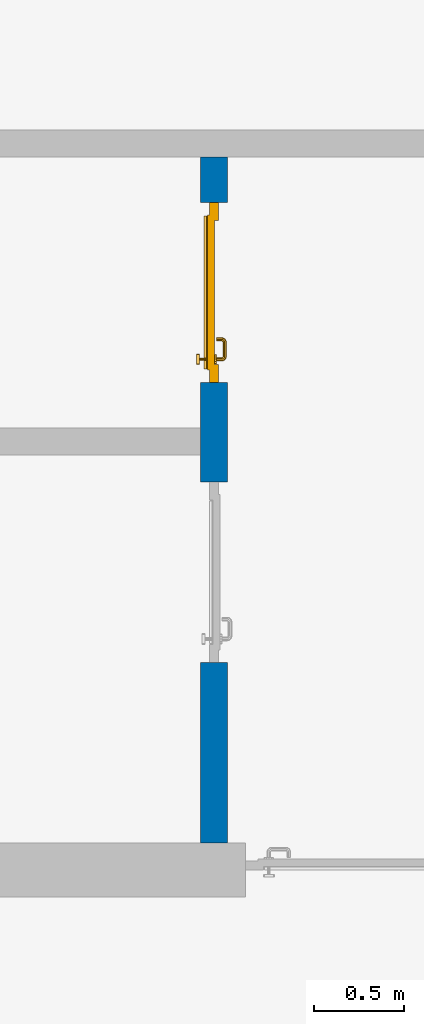
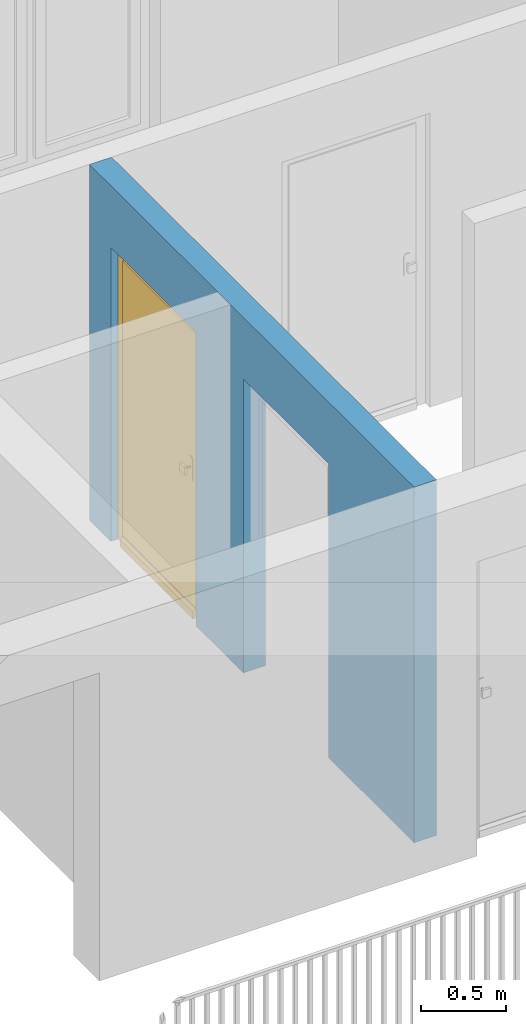
# One storey, part 18 of 54: 1 door, 1 wall, 2 openings.
"""IFC4 building model written with IfcOpenShell, lengths in metres."""

import ifcopenshell
import ifcopenshell.guid

model = None  # the IFC model being written
_history = None  # IfcOwnerHistory: only IFC2X3 demands one
_inside = {}  # id of a spatial element -> (the spatial element, [elements in it])
_under = {}  # id of a project, library or spatial element -> (it, [spatial elements below it])
_declared = {}  # id of a project -> (the project, [libraries it declares])
_typed = {}  # id of a type object -> (the type object, [elements of that type])
_made_of = {}  # id of a material, layer set ... -> (it, [elements and type objects made of it])


def new_model(schema):
    """Start an empty IFC model of exactly this schema.

    Asked for "IFC4X3", IfcOpenShell would pick the latest addendum, in which some entities
    have other attributes; the version numbers below select the first issue.
    IFC2X3 requires an IfcOwnerHistory on every rooted entity: one is made here for all.
    """
    global model, _history
    if schema == "IFC4X3":
        model = ifcopenshell.file(schema_version=(4, 3, 0, 0))
    else:
        model = ifcopenshell.file(schema=schema)
    _inside.clear()
    _under.clear()
    _declared.clear()
    _typed.clear()
    _made_of.clear()
    _history = None
    if model.schema == "IFC2X3":
        org = make("IfcOrganization", Name="unknown")
        user = make(
            "IfcPersonAndOrganization",
            ThePerson=make("IfcPerson", FamilyName="unknown"),
            TheOrganization=org,
        )
        app = make(
            "IfcApplication",
            ApplicationDeveloper=org,
            Version="unknown",
            ApplicationFullName="unknown",
            ApplicationIdentifier="unknown",
        )
        _history = make(
            "IfcOwnerHistory",
            OwningUser=user,
            OwningApplication=app,
            ChangeAction="ADDED",
            CreationDate=0,
        )
    return model


def make(cls, **values):
    """One entity of the class cls with the attributes given. An attribute that is None is left unset."""
    return model.create_entity(
        cls, **{name: value for name, value in values.items() if value is not None}
    )


def entity(cls, *values):
    """Any entity or typed value of the class cls, its attributes in the order of the schema. None: left unset."""
    e = model.create_entity(cls)
    for i, value in enumerate(values):
        if value is not None:
            e[i] = value
    return e


def rooted(cls, **values):
    """An entity with a GlobalId (a new one), such as an element, a storey or a relation."""
    return make(cls, GlobalId=ifcopenshell.guid.new(), OwnerHistory=_history, **values)


def si_unit(unit_type, name, prefix=None):
    """IfcSIUnit, for example si_unit("LENGTHUNIT", "METRE", prefix="MILLI")."""
    return make("IfcSIUnit", UnitType=unit_type, Prefix=prefix, Name=name)


def converted_unit(unit_type, name, factor, base, dimensions=None, offset=None):
    """IfcConversionBasedUnit, such as the inch: factor (a typed value) times the base unit."""
    return make(
        "IfcConversionBasedUnit"
        if offset is None
        else "IfcConversionBasedUnitWithOffset",
        ConversionOffset=offset,
        Dimensions=None
        if dimensions is None
        else entity("IfcDimensionalExponents", *dimensions),
        UnitType=unit_type,
        Name=name,
        ConversionFactor=make(
            "IfcMeasureWithUnit", ValueComponent=factor, UnitComponent=base
        ),
    )


def derived_unit(unit_type, elements):
    """IfcDerivedUnit: a product of units, each with its exponent."""
    return make(
        "IfcDerivedUnit",
        Elements=[
            make("IfcDerivedUnitElement", Unit=unit, Exponent=power)
            for unit, power in elements
        ],
        UnitType=unit_type,
    )


def assignment(units):
    """IfcUnitAssignment: the units of a project."""
    return None if units is None else make("IfcUnitAssignment", Units=units)


def point(xyz):
    """IfcCartesianPoint."""
    return None if xyz is None else make("IfcCartesianPoint", Coordinates=xyz)


def direction(xyz):
    """IfcDirection."""
    return None if xyz is None else make("IfcDirection", DirectionRatios=xyz)


def frame(location, z_axis=None, x_axis=None):
    """IfcAxis2Placement3D, a coordinate frame: its origin and axes. An axis left out is left unset."""
    return make(
        "IfcAxis2Placement3D",
        Location=point(location),
        Axis=direction(z_axis),
        RefDirection=direction(x_axis),
    )


def origin_with_axes():
    """The frame at (0, 0, 0) with the z axis (0, 0, 1) and the x axis (1, 0, 0) written out."""
    return frame((0.0, 0.0, 0.0), z_axis=(0.0, 0.0, 1.0), x_axis=(1.0, 0.0, 0.0))


def place(relative_to, where):
    """IfcLocalPlacement: puts the frame where relative to a parent placement (None: the world)."""
    return make(
        "IfcLocalPlacement", PlacementRelTo=relative_to, RelativePlacement=where
    )


def context(
    kind, dimensions, precision=None, world=None, true_north=None, identifier=None
):
    """IfcGeometricRepresentationContext, for example the 3D "Model" context."""
    return make(
        "IfcGeometricRepresentationContext",
        ContextIdentifier=identifier,
        ContextType=kind,
        CoordinateSpaceDimension=dimensions,
        Precision=precision,
        WorldCoordinateSystem=world,
        TrueNorth=true_north,
    )


def subcontext(parent, identifier, kind, view, scale=None):
    """IfcGeometricRepresentationSubContext, for example "Body" below "Model"."""
    return make(
        "IfcGeometricRepresentationSubContext",
        ContextIdentifier=identifier,
        ContextType=kind,
        ParentContext=parent,
        TargetScale=scale,
        TargetView=view,
    )


def project(units=None, contexts=None):
    """IfcProject with its units and contexts."""
    return rooted(
        "IfcProject",
        Name="project",
        RepresentationContexts=contexts,
        UnitsInContext=assignment(units),
    )


def spatial(cls, under=None, at=None, **own):
    """A site, building, storey or space (cls), placed at a placement, below another one or the project."""
    s = rooted(cls, ObjectPlacement=at, **own)
    if under is not None:
        _under.setdefault(under.id(), (under, []))[1].append(s)
    return s


def point_list(points):
    """IfcCartesianPointList2D or 3D."""
    cls = (
        "IfcCartesianPointList2D" if len(points[0]) == 2 else "IfcCartesianPointList3D"
    )
    return make(cls, CoordList=points)


def polygons(points, faces, closed=None, point_numbers=None):
    """IfcPolygonalFaceSet: a face is its outer loop, then its inner loops; points numbered from 1."""
    made = []
    for loops in faces:
        if len(loops) == 1:
            made.append(make("IfcIndexedPolygonalFace", CoordIndex=loops[0]))
        else:
            made.append(
                make(
                    "IfcIndexedPolygonalFaceWithVoids",
                    CoordIndex=loops[0],
                    InnerCoordIndices=loops[1:],
                )
            )
    return make(
        "IfcPolygonalFaceSet",
        Coordinates=point_list(points),
        Closed=closed,
        Faces=made,
        PnIndex=point_numbers,
    )


def shape(context_of_items, identifier, shape_type, items):
    """IfcShapeRepresentation: the items that make up one representation, for example the "Body"."""
    return make(
        "IfcShapeRepresentation",
        ContextOfItems=context_of_items,
        RepresentationIdentifier=identifier,
        RepresentationType=shape_type,
        Items=items,
    )


def source(mapping_origin, context_of_items, identifier, shape_type, items):
    """IfcRepresentationMap: a shape defined once, which mapped items show again and again."""
    return make(
        "IfcRepresentationMap",
        MappingOrigin=mapping_origin,
        MappedRepresentation=shape(context_of_items, identifier, shape_type, items),
    )


def transform(
    local_origin,
    x_axis=None,
    y_axis=None,
    z_axis=None,
    scale=None,
    scale2=None,
    scale3=None,
    uniform=True,
):
    """IfcCartesianTransformationOperator3D, or its non-uniform kind. x_axis, y_axis, z_axis: its Axis1, 2, 3."""
    if uniform:
        return make(
            "IfcCartesianTransformationOperator3D",
            Axis1=direction(x_axis),
            Axis2=direction(y_axis),
            LocalOrigin=point(local_origin),
            Scale=scale,
            Axis3=direction(z_axis),
        )
    return make(
        "IfcCartesianTransformationOperator3DnonUniform",
        Axis1=direction(x_axis),
        Axis2=direction(y_axis),
        LocalOrigin=point(local_origin),
        Scale=scale,
        Axis3=direction(z_axis),
        Scale2=scale2,
        Scale3=scale3,
    )


def mapped(mapping_source, mapping_target):
    """IfcMappedItem: shows the shape of a source again, moved by a transform."""
    return make(
        "IfcMappedItem", MappingSource=mapping_source, MappingTarget=mapping_target
    )


def material(Name=None, Category=None):
    """IfcMaterial."""
    return make("IfcMaterial", Name=Name, Category=Category)


def made_of(thing, what):
    """Note that an element or type object is made of a material, layer set ...; save() writes the relation."""
    if what is not None:
        _made_of.setdefault(what.id(), (what, []))[1].append(thing)
    return thing


def type_object(cls, material=None, **own):
    """A type object (cls), such as IfcWallType, which elements share."""
    return made_of(rooted(cls, **own), material)


def element(
    cls,
    number,
    at=None,
    inside=None,
    cuts=None,
    type_object=None,
    material=None,
    context=None,
    identifier="Body",
    shape_type=None,
    held_by="IfcProductDefinitionShape",
    body=None,
    shapes=None,
    **own,
):
    """One element of the class cls, such as IfcWall. Its Tag is "e" and its number.

    at: its placement. inside: the storey or other place that contains it. cuts: it is an
    opening in that element (IfcRelVoidsElement). A single representation is given by context,
    identifier, shape_type and body (its items); several are given by shapes. held_by: the class
    of the entity that holds the representations. save() writes the other relations.
    """
    e = rooted(cls, Tag="e%d" % number, ObjectPlacement=at, **own)
    if body is not None:
        shapes = [shape(context, identifier, shape_type, body)]
    if shapes is not None:
        e.Representation = make(held_by, Representations=shapes)
    if inside is not None:
        _inside.setdefault(inside.id(), (inside, []))[1].append(e)
    if cuts is not None:
        rooted(
            "IfcRelVoidsElement", RelatingBuildingElement=cuts, RelatedOpeningElement=e
        )
    if type_object is not None:
        _typed.setdefault(type_object.id(), (type_object, []))[1].append(e)
    return made_of(e, material)


def fill(opening, filler):
    """IfcRelFillsElement: the door or window that sits in an opening."""
    return rooted(
        "IfcRelFillsElement",
        RelatingOpeningElement=opening,
        RelatedBuildingElement=filler,
    )


def aggregate(whole, parts):
    """IfcRelAggregates: a whole, such as a stair, and the parts it consists of."""
    return rooted("IfcRelAggregates", RelatingObject=whole, RelatedObjects=parts)


def save(model, path):
    """Write the relations noted so far, then the file.

    IfcRelAggregates (storeys below a building ...), IfcRelContainedInSpatialStructure (elements
    in a storey), IfcRelDefinesByType, IfcRelAssociatesMaterial and IfcRelDeclares: one each for
    every whole, place, type object, material and project.
    """
    for whole, parts in _under.values():
        aggregate(whole, parts)
    for where, things in _inside.values():
        rooted(
            "IfcRelContainedInSpatialStructure",
            RelatedElements=things,
            RelatingStructure=where,
        )
    for kind, things in _typed.values():
        rooted("IfcRelDefinesByType", RelatedObjects=things, RelatingType=kind)
    for what, things in _made_of.values():
        rooted("IfcRelAssociatesMaterial", RelatedObjects=things, RelatingMaterial=what)
    for by, libraries in _declared.values():
        rooted("IfcRelDeclares", RelatingContext=by, RelatedDefinitions=libraries)
    model.write(path)


model = new_model("IFC4")

# Units and contexts
model_context = context("Model", 3, precision=1e-05, world=origin_with_axes(), true_north=direction((0.0, 1.0)))
body_context = subcontext(model_context, "Body", "Model", "MODEL_VIEW")
ifc_project = project(units=[si_unit("LENGTHUNIT", "METRE"), si_unit("AREAUNIT", "SQUARE_METRE"), si_unit("VOLUMEUNIT", "CUBIC_METRE"), converted_unit("PLANEANGLEUNIT", "DEGREE", entity("IfcPlaneAngleMeasure", 0.0174532925199), si_unit("PLANEANGLEUNIT", "RADIAN"), dimensions=[0, 0, 0, 0, 0, 0, 0]), converted_unit("TIMEUNIT", "Year", entity("IfcTimeMeasure", 31556926.0), si_unit("TIMEUNIT", "SECOND"), dimensions=[0, 0, 1, 0, 0, 0, 0]), si_unit("MASSUNIT", "GRAM", prefix="KILO"), si_unit("THERMODYNAMICTEMPERATUREUNIT", "DEGREE_CELSIUS"), si_unit("LUMINOUSINTENSITYUNIT", "LUMEN"), si_unit("ENERGYUNIT", "JOULE", prefix="MEGA"), derived_unit("THERMALCONDUCTANCEUNIT", [(si_unit("POWERUNIT", "WATT"), 1), (si_unit("LENGTHUNIT", "METRE"), -1), (si_unit("THERMODYNAMICTEMPERATUREUNIT", "KELVIN"), -1)]), derived_unit("SPECIFICHEATCAPACITYUNIT", [(si_unit("ENERGYUNIT", "JOULE"), 1), (si_unit("MASSUNIT", "GRAM", prefix="KILO"), -1), (si_unit("THERMODYNAMICTEMPERATUREUNIT", "KELVIN"), -1)]), derived_unit("MASSDENSITYUNIT", [(si_unit("MASSUNIT", "GRAM", prefix="KILO"), 1), (si_unit("VOLUMEUNIT", "CUBIC_METRE"), -1)])], contexts=[model_context])

# Site, building, storey
site_placement = place(None, origin_with_axes())
site = spatial("IfcSite", under=ifc_project, at=site_placement, CompositionType="ELEMENT")
building_placement = place(site_placement, origin_with_axes())
building = spatial("IfcBuilding", under=site, at=building_placement, CompositionType="ELEMENT")
storey_placement = place(building_placement, frame((0.0, 0.0, 9.18), z_axis=(0.0, 0.0, 1.0), x_axis=(1.0, 0.0, 0.0)))
storey = spatial("IfcBuildingStorey", under=building, at=storey_placement, Name="3. Geschoss", CompositionType="ELEMENT", Elevation=9.18)

# Wall, openings, door
ifc_material = material()
wall_type = type_object("IfcWallType", Name="150", PredefinedType="NOTDEFINED")
wall_placement = place(storey_placement, frame((1.3378006196, 1.37118776896, 0.0), z_axis=(0.0, 0.0, 1.0), x_axis=(0.0, 1.0, 0.0)))
wall = element("IfcWall", 1, at=wall_placement, inside=storey, type_object=wall_type, material=ifc_material, Name="Wand-002", PredefinedType="NOTDEFINED", context=body_context, shape_type="Tessellation", body=[
    polygons([(1.3, 0.0, 0.0), (1.3, 0.0, 2.1), (2.3, 0.0, 2.1), (2.3, 0.0, 0.0), (2.85, 0.0, 0.0), (2.85, 0.0, 2.1), (3.85, 0.0, 2.1), (3.85, 0.0, 0.0), (4.1, 0.0, 0.0), (4.1, 0.0, 2.54), (0.3, 0.0, 2.54), (0.3, 0.0, 0.0), (1.3, 0.1, 0.0), (1.3, 0.15, 0.0), (1.3, 0.15, 2.1), (2.3, 0.15, 2.1), (2.3, 0.1, 0.0), (2.3, 0.15, 0.0), (2.85, 0.15, 0.0), (2.85, 0.15, 2.1), (3.85, 0.15, 2.1), (3.85, 0.15, 0.0), (4.1, 0.15, 0.0), (4.1, 0.15, 2.54), (0.3, 0.15, 2.54), (0.3, 0.15, 0.0)], [[[1, 2, 3, 4, 5, 6, 7, 8, 9, 10, 11, 12]], [[2, 1, 13, 14, 15]], [[3, 2, 15, 16]], [[17, 4, 3, 16, 18]], [[4, 17, 18, 19, 5]], [[19, 20, 6, 5]], [[20, 21, 7, 6]], [[21, 22, 8, 7]], [[23, 9, 8, 22]], [[23, 24, 10, 9]], [[25, 11, 10, 24]], [[12, 11, 25, 26]], [[13, 1, 12, 26, 14]], [[19, 18, 16, 15, 14, 26, 25, 24, 23, 22, 21, 20]]], closed=True),
])
opening_1_placement = place(wall_placement, frame((3.35, 0.0, 0.0), z_axis=(0.0, 0.0, 1.0), x_axis=(1.0, 0.0, 0.0)))
opening_1 = element("IfcOpeningElement", 2, at=opening_1_placement, cuts=wall, context=body_context, identifier="Reference", shape_type="Tessellation", body=[
    polygons([(-0.5, 0.1, 0.0), (-0.5, 0.1, 2.1), (-0.5, 0.151, 2.1), (-0.5, 0.151, 0.0), (-0.5, -0.001, 0.0), (-0.5, -0.001, 2.1), (0.5, 0.1, 2.1), (0.5, 0.151, 2.1), (0.5, -0.001, 2.1), (0.5, 0.151, 0.0), (0.5, 0.1, 0.0), (0.5, -0.001, 0.0)], [[[1, 2, 3, 4]], [[2, 1, 5, 6]], [[7, 8, 3, 2, 6, 9]], [[8, 10, 4, 3]], [[1, 4, 10, 11, 12, 5]], [[6, 5, 12, 9]], [[7, 11, 10, 8]], [[11, 7, 9, 12]]], closed=True),
])
opening_2_placement = place(wall_placement, frame((1.8, 0.0, 0.0), z_axis=(0.0, 0.0, 1.0), x_axis=(1.0, 0.0, 0.0)))
element("IfcOpeningElement", 3, at=opening_2_placement, cuts=wall, context=body_context, identifier="Reference", shape_type="Tessellation", body=[
    polygons([(-0.5, 0.1, 0.0), (-0.5, 0.1, 2.1), (-0.5, 0.151, 2.1), (-0.5, 0.151, 0.0), (-0.5, -0.001, 0.0), (-0.5, -0.001, 2.1), (0.5, 0.1, 2.1), (0.5, 0.151, 2.1), (0.5, -0.001, 2.1), (0.5, 0.151, 0.0), (0.5, 0.1, 0.0), (0.5, -0.001, 0.0)], [[[1, 2, 3, 4]], [[2, 1, 5, 6]], [[7, 8, 3, 2, 6, 9]], [[8, 10, 4, 3]], [[1, 4, 10, 11, 12, 5]], [[6, 5, 12, 9]], [[7, 11, 10, 8]], [[11, 7, 9, 12]]], closed=True),
])
door_type = type_object("IfcDoorType", Name="Eingang 01 1-Fl 26", OperationType="SINGLE_SWING_RIGHT", PredefinedType="DOOR")
shared_shape = source(origin_with_axes(), body_context, "Body", "Tessellation", [
    polygons([(0.5, -0.05, 0.0), (0.5, -0.03, 0.0), (0.5, -0.03, 2.1), (0.5, -0.05, 2.1), (0.4, -0.05, 0.0), (0.4, -0.03, 0.0), (0.4, -0.03, 2.0), (0.1301, -0.03, 2.0), (0.0001, -0.03, 2.0), (-0.4, -0.03, 2.0), (-0.4, -0.03, 0.0), (-0.5, -0.03, 0.0), (-0.5, -0.03, 2.1), (-0.5, -0.05, 2.1), (-0.5, -0.05, 0.0), (-0.4, -0.05, 0.0), (-0.4, -0.05, 2.0), (0.0001, -0.05, 2.0), (0.1301, -0.05, 2.0), (0.4, -0.05, 2.0)], [[[1, 2, 3, 4]], [[5, 6, 2, 1]], [[2, 6, 7, 8, 9, 10, 11, 12, 13, 3]], [[4, 3, 13, 14]], [[1, 4, 14, 15, 16, 17, 18, 19, 20, 5]], [[20, 7, 6, 5]], [[19, 8, 7, 20]], [[18, 9, 8, 19]], [[17, 10, 9, 18]], [[16, 11, 10, 17]], [[15, 12, 11, 16]], [[14, 13, 12, 15]]], closed=True),
    polygons([(0.5, -0.03, 0.0), (0.5, 0.0, 0.0), (0.5, 0.0, 2.1), (0.5, -0.03, 2.1), (0.43, -0.03, 0.0), (0.43, 0.0, 0.0), (0.43, 0.0, 2.03), (0.1001, 0.0, 2.03), (0.0301, 0.0, 2.03), (-0.43, 0.0, 2.03), (-0.43, 0.0, 0.0), (-0.5, 0.0, 0.0), (-0.5, 0.0, 2.1), (-0.5, -0.03, 2.1), (-0.5, -0.03, 0.0), (-0.43, -0.03, 0.0), (-0.43, -0.03, 2.03), (0.0301, -0.03, 2.03), (0.1001, -0.03, 2.03), (0.43, -0.03, 2.03)], [[[1, 2, 3, 4]], [[5, 6, 2, 1]], [[2, 6, 7, 8, 9, 10, 11, 12, 13, 3]], [[4, 3, 13, 14]], [[1, 4, 14, 15, 16, 17, 18, 19, 20, 5]], [[20, 7, 6, 5]], [[19, 8, 7, 20]], [[18, 9, 8, 19]], [[17, 10, 9, 18]], [[16, 11, 10, 17]], [[15, 12, 11, 16]], [[14, 13, 12, 15]]], closed=True),
    polygons([(0.43, 0.01, 0.0), (-0.43, 0.01, 0.0), (-0.43, 0.01, 2.03), (0.43, 0.01, 2.03), (0.43, -0.03, 0.0), (-0.43, -0.03, 0.0), (-0.43, -0.03, 2.03), (0.43, -0.03, 2.03)], [[[1, 2, 3, 4]], [[2, 1, 5, 6]], [[3, 2, 6, 7]], [[4, 3, 7, 8]], [[1, 4, 8, 5]], [[6, 5, 8, 7]]], closed=True),
    polygons([(0.425, 0.03, 0.0), (-0.425, 0.03, 0.0), (-0.425, 0.03, 0.05), (0.425, 0.03, 0.05), (0.425, 0.01, 0.0), (-0.425, 0.01, 0.0), (-0.425, 0.01, 0.07), (-0.425, 0.015, 0.07), (0.425, 0.015, 0.07), (0.425, 0.01, 0.07)], [[[1, 2, 3, 4]], [[5, 6, 2, 1]], [[2, 6, 7, 8, 3]], [[4, 3, 8, 9]], [[1, 4, 9, 10, 5]], [[10, 7, 6, 5]], [[9, 8, 7, 10]]], closed=True),
    polygons([(-0.3835, -0.04, 1.0733826859), (-0.37, -0.04, 1.077), (-0.37, -0.0399, 1.077), (-0.3835, -0.0399, 1.0733826859), (-0.393382685902, -0.04, 1.0635), (-0.397, -0.04, 1.05), (-0.393382685902, -0.04, 1.0365), (-0.3835, -0.04, 1.0266173141), (-0.37, -0.04, 1.023), (-0.3565, -0.04, 1.0266173141), (-0.346617314098, -0.04, 1.0365), (-0.343, -0.04, 1.05), (-0.346617314098, -0.04, 1.0635), (-0.3565, -0.04, 1.0733826859), (-0.3565, -0.0399, 1.0733826859), (-0.37, -0.0301, 1.077), (-0.3835, -0.0301, 1.0733826859), (-0.393382685902, -0.0399, 1.0635), (-0.397, -0.0399, 1.05), (-0.393382685902, -0.0399, 1.0365), (-0.3835, -0.0399, 1.0266173141), (-0.37, -0.0399, 1.023), (-0.3565, -0.0399, 1.0266173141), (-0.346617314098, -0.0399, 1.0365), (-0.343, -0.0399, 1.05), (-0.346617314098, -0.0399, 1.0635), (-0.3565, -0.0301, 1.0733826859), (-0.37, -0.03, 1.077), (-0.3835, -0.03, 1.0733826859), (-0.393382685902, -0.0301, 1.0635), (-0.397, -0.0301, 1.05), (-0.393382685902, -0.0301, 1.0365), (-0.3835, -0.0301, 1.0266173141), (-0.37, -0.0301, 1.023), (-0.3565, -0.0301, 1.0266173141), (-0.346617314098, -0.0301, 1.0365), (-0.343, -0.0301, 1.05), (-0.346617314098, -0.0301, 1.0635), (-0.3565, -0.03, 1.0733826859), (-0.346617314098, -0.03, 1.0635), (-0.343, -0.03, 1.05), (-0.346617314098, -0.03, 1.0365), (-0.3565, -0.03, 1.0266173141), (-0.37, -0.03, 1.023), (-0.3835, -0.03, 1.0266173141), (-0.393382685902, -0.03, 1.0365), (-0.397, -0.03, 1.05), (-0.393382685902, -0.03, 1.0635)], [[[1, 2, 3, 4]], [[2, 1, 5, 6, 7, 8, 9, 10, 11, 12, 13, 14]], [[2, 14, 15, 3]], [[4, 3, 16, 17]], [[5, 1, 4, 18]], [[6, 5, 18, 19]], [[7, 6, 19, 20]], [[8, 7, 20, 21]], [[9, 8, 21, 22]], [[10, 9, 22, 23]], [[11, 10, 23, 24]], [[12, 11, 24, 25]], [[13, 12, 25, 26]], [[14, 13, 26, 15]], [[3, 15, 27, 16]], [[17, 16, 28, 29]], [[18, 4, 17, 30]], [[19, 18, 30, 31]], [[20, 19, 31, 32]], [[21, 20, 32, 33]], [[22, 21, 33, 34]], [[23, 22, 34, 35]], [[24, 23, 35, 36]], [[25, 24, 36, 37]], [[26, 25, 37, 38]], [[15, 26, 38, 27]], [[16, 27, 39, 28]], [[28, 39, 40, 41, 42, 43, 44, 45, 46, 47, 48, 29]], [[30, 17, 29, 48]], [[31, 30, 48, 47]], [[32, 31, 47, 46]], [[33, 32, 46, 45]], [[34, 33, 45, 44]], [[35, 34, 44, 43]], [[36, 35, 43, 42]], [[37, 36, 42, 41]], [[38, 37, 41, 40]], [[27, 38, 40, 39]]], closed=True),
    polygons([(-0.362532169224, -0.04, 0.959692280177), (-0.365, -0.04, 0.9544), (-0.365, -0.04, 0.952886751346), (-0.346703916638, -0.04, 0.96345), (-0.35655, -0.04, 0.973296083362), (-0.363279754556, -0.04, 0.961639806549), (-0.362532169224, -0.039, 0.959692280177), (-0.365, -0.039, 0.9544), (-0.365, -0.039, 0.952886751346), (-0.365, -0.039, 0.95), (-0.365, -0.039, 0.947113248654), (-0.365, -0.039, 0.941339745962), (-0.365, -0.039, 0.9375), (-0.365, -0.04, 0.9375), (-0.365, -0.04, 0.941339745962), (-0.365, -0.04, 0.947113248654), (-0.365, -0.04, 0.95), (-0.3431, -0.04, 0.95), (-0.346617314098, -0.04, 0.9635), (-0.3565, -0.04, 0.973382685902), (-0.364624817685, -0.04, 0.965143815798), (-0.37, -0.04, 0.9769), (-0.37, -0.04, 0.967425445323), (-0.364624817685, -0.039, 0.965143815798), (-0.363279754556, -0.039, 0.961639806549), (-0.35705, -0.039, 0.972430057958), (-0.347569942042, -0.039, 0.96295), (-0.3441, -0.039, 0.95), (-0.347569942042, -0.039, 0.93705), (-0.35705, -0.039, 0.927569942042), (-0.37, -0.039, 0.9241), (-0.37, -0.039, 0.9325), (-0.366464466094, -0.039, 0.933964466094), (-0.366464466094, -0.04, 0.933964466094), (-0.35655, -0.04, 0.926703916638), (-0.37, -0.04, 0.9325), (-0.37, -0.04, 0.9231), (-0.346703916638, -0.04, 0.93655), (-0.343, -0.04, 0.95), (-0.346617314098, -0.0399, 0.9635), (-0.3565, -0.0399, 0.973382685902), (-0.37, -0.04, 0.977), (-0.375375182315, -0.04, 0.965143815798), (-0.38345, -0.04, 0.973296083362), (-0.376720245444, -0.04, 0.961639806549), (-0.37, -0.039, 0.967425445323), (-0.37, -0.039, 0.9759), (-0.357, -0.039, 0.972516660498), (-0.347483339502, -0.039, 0.963), (-0.344, -0.039, 0.95), (-0.347483339502, -0.039, 0.937), (-0.357, -0.039, 0.927483339502), (-0.38295, -0.039, 0.927569942042), (-0.375, -0.039, 0.941339745962), (-0.375, -0.039, 0.9375), (-0.373535533906, -0.039, 0.933964466094), (-0.37, -0.039, 0.924), (-0.373535533906, -0.04, 0.933964466094), (-0.375, -0.04, 0.9375), (-0.375, -0.04, 0.941339745962), (-0.38345, -0.04, 0.926703916638), (-0.37, -0.04, 0.923), (-0.3565, -0.04, 0.926617314098), (-0.346617314098, -0.04, 0.9365), (-0.343, -0.0399, 0.95), (-0.346617314098, -0.0301, 0.9635), (-0.3565, -0.0301, 0.973382685902), (-0.37, -0.0399, 0.977), (-0.3835, -0.04, 0.973382685902), (-0.375375182315, -0.039, 0.965143815798), (-0.377467830776, -0.04, 0.959692280177), (-0.393296083362, -0.04, 0.96345), (-0.375, -0.04, 0.952886751346), (-0.375, -0.04, 0.9544), (-0.377467830776, -0.039, 0.959692280177), (-0.376720245444, -0.039, 0.961639806549), (-0.38295, -0.039, 0.972430057958), (-0.37, -0.039, 0.976), (-0.357, -0.0389, 0.972516660498), (-0.347483339502, -0.0389, 0.963), (-0.344, -0.0389, 0.95), (-0.347483339502, -0.0389, 0.937), (-0.357, -0.0389, 0.927483339502), (-0.392430057958, -0.039, 0.93705), (-0.375, -0.039, 0.947113248654), (-0.375, -0.039, 0.9544), (-0.375, -0.04, 0.95), (-0.375, -0.04, 0.947113248654), (-0.375, -0.039, 0.95), (-0.375, -0.039, 0.952886751346), (-0.383, -0.039, 0.927483339502), (-0.37, -0.0389, 0.924), (-0.393296083362, -0.04, 0.93655), (-0.3835, -0.04, 0.926617314098), (-0.37, -0.0399, 0.923), (-0.3565, -0.0399, 0.926617314098), (-0.346617314098, -0.0399, 0.9365), (-0.343, -0.0301, 0.95), (-0.346617314098, -0.03, 0.9635), (-0.3565, -0.03, 0.973382685902), (-0.37, -0.0301, 0.977), (-0.3835, -0.0399, 0.973382685902), (-0.393382685902, -0.04, 0.9635), (-0.3969, -0.04, 0.95), (-0.392430057958, -0.039, 0.96295), (-0.383, -0.039, 0.972516660498), (-0.37, -0.0389, 0.976), (-0.357, -0.0301, 0.972516660498), (-0.347483339502, -0.0301, 0.963), (-0.344, -0.0301, 0.95), (-0.347483339502, -0.0301, 0.937), (-0.357, -0.0301, 0.927483339502), (-0.392516660498, -0.039, 0.937), (-0.3959, -0.039, 0.95), (-0.383, -0.0389, 0.927483339502), (-0.37, -0.0301, 0.924), (-0.393382685902, -0.04, 0.9365), (-0.3835, -0.0399, 0.926617314098), (-0.37, -0.0301, 0.923), (-0.3565, -0.0301, 0.926617314098), (-0.346617314098, -0.0301, 0.9365), (-0.343, -0.03, 0.95), (-0.346703916638, -0.03, 0.96345), (-0.35655, -0.03, 0.973296083362), (-0.37, -0.03, 0.977), (-0.3835, -0.0301, 0.973382685902), (-0.393382685902, -0.0399, 0.9635), (-0.397, -0.04, 0.95), (-0.392516660498, -0.039, 0.963), (-0.383, -0.0389, 0.972516660498), (-0.37, -0.0301, 0.976), (-0.357, -0.03, 0.972516660498), (-0.347483339502, -0.03, 0.963), (-0.344, -0.03, 0.95), (-0.347483339502, -0.03, 0.937), (-0.357, -0.03, 0.927483339502), (-0.392516660498, -0.0389, 0.937), (-0.396, -0.039, 0.95), (-0.383, -0.0301, 0.927483339502), (-0.37, -0.03, 0.924), (-0.393382685902, -0.0399, 0.9365), (-0.3835, -0.0301, 0.926617314098), (-0.37, -0.03, 0.923), (-0.3565, -0.03, 0.926617314098), (-0.346617314098, -0.03, 0.9365), (-0.3431, -0.03, 0.95), (-0.347396736961, -0.03, 0.96305), (-0.35695, -0.03, 0.972603263039), (-0.37, -0.03, 0.9769), (-0.3835, -0.03, 0.973382685902), (-0.393382685902, -0.0301, 0.9635), (-0.397, -0.0399, 0.95), (-0.392516660498, -0.0389, 0.963), (-0.383, -0.0301, 0.972516660498), (-0.37, -0.03, 0.976), (-0.3439, -0.03, 0.95), (-0.347396736961, -0.03, 0.93695), (-0.35695, -0.03, 0.927396736961), (-0.392516660498, -0.0301, 0.937), (-0.396, -0.0389, 0.95), (-0.383, -0.03, 0.927483339502), (-0.37, -0.03, 0.9239), (-0.393382685902, -0.0301, 0.9365), (-0.3835, -0.03, 0.926617314098), (-0.37, -0.03, 0.9231), (-0.35655, -0.03, 0.926703916638), (-0.346703916638, -0.03, 0.93655), (-0.37, -0.03, 0.9761), (-0.38345, -0.03, 0.973296083362), (-0.393382685902, -0.03, 0.9635), (-0.397, -0.0301, 0.95), (-0.392516660498, -0.0301, 0.963), (-0.383, -0.03, 0.972516660498), (-0.392516660498, -0.03, 0.937), (-0.396, -0.0301, 0.95), (-0.38305, -0.03, 0.927396736961), (-0.393382685902, -0.03, 0.9365), (-0.38345, -0.03, 0.926703916638), (-0.38305, -0.03, 0.972603263039), (-0.393296083362, -0.03, 0.96345), (-0.397, -0.03, 0.95), (-0.392516660498, -0.03, 0.963), (-0.392603263039, -0.03, 0.93695), (-0.396, -0.03, 0.95), (-0.393296083362, -0.03, 0.93655), (-0.392603263039, -0.03, 0.96305), (-0.3969, -0.03, 0.95), (-0.3961, -0.03, 0.95)], [[[1, 2, 3, 4, 5, 6]], [[2, 1, 7, 8]], [[2, 8, 9, 10, 11, 12, 13, 14, 15, 16, 17, 3]], [[17, 18, 4, 3]], [[19, 20, 5, 4]], [[21, 6, 5, 22, 23]], [[1, 6, 21, 24, 25, 7]], [[7, 25, 26, 27, 9, 8]], [[9, 27, 28, 10]], [[10, 28, 29, 11]], [[11, 29, 30, 12]], [[31, 32, 33, 13, 12, 30]], [[14, 13, 33, 34]], [[35, 15, 14, 34, 36, 37]], [[15, 35, 38, 16]], [[16, 38, 18, 17]], [[39, 19, 4, 18]], [[40, 41, 20, 19]], [[20, 42, 22, 5]], [[43, 23, 22, 44, 45]], [[21, 23, 46, 24]], [[24, 46, 47, 26, 25]], [[27, 26, 48, 49]], [[28, 27, 49, 50]], [[29, 28, 50, 51]], [[30, 29, 51, 52]], [[53, 54, 55, 56, 32, 31]], [[34, 33, 32, 36]], [[31, 30, 52, 57]], [[37, 36, 58, 59, 60, 61]], [[62, 63, 35, 37]], [[63, 64, 38, 35]], [[64, 39, 18, 38]], [[65, 40, 19, 39]], [[66, 67, 41, 40]], [[41, 68, 42, 20]], [[42, 69, 44, 22]], [[23, 43, 70, 46]], [[71, 45, 44, 72, 73, 74]], [[43, 45, 71, 75, 76, 70]], [[70, 76, 77, 47, 46]], [[26, 47, 78, 48]], [[49, 48, 79, 80]], [[50, 49, 80, 81]], [[51, 50, 81, 82]], [[52, 51, 82, 83]], [[54, 53, 84, 85]], [[86, 74, 73, 87, 88, 60, 59, 55, 54, 85, 89, 90]], [[58, 56, 55, 59]], [[36, 32, 56, 58]], [[53, 31, 57, 91]], [[57, 52, 83, 92]], [[88, 93, 61, 60]], [[94, 62, 37, 61]], [[95, 96, 63, 62]], [[96, 97, 64, 63]], [[97, 65, 39, 64]], [[98, 66, 40, 65]], [[99, 100, 67, 66]], [[67, 101, 68, 41]], [[68, 102, 69, 42]], [[69, 103, 72, 44]], [[73, 72, 104, 87]], [[71, 74, 86, 75]], [[75, 86, 90, 105, 77, 76]], [[47, 77, 106, 78]], [[48, 78, 107, 79]], [[80, 79, 108, 109]], [[81, 80, 109, 110]], [[82, 81, 110, 111]], [[83, 82, 111, 112]], [[84, 53, 91, 113]], [[85, 84, 114, 89]], [[87, 104, 93, 88]], [[89, 114, 105, 90]], [[91, 57, 92, 115]], [[92, 83, 112, 116]], [[117, 94, 61, 93]], [[118, 95, 62, 94]], [[119, 120, 96, 95]], [[120, 121, 97, 96]], [[121, 98, 65, 97]], [[122, 99, 66, 98]], [[123, 124, 100, 99]], [[100, 125, 101, 67]], [[101, 126, 102, 68]], [[102, 127, 103, 69]], [[103, 128, 104, 72]], [[77, 105, 129, 106]], [[78, 106, 130, 107]], [[79, 107, 131, 108]], [[109, 108, 132, 133]], [[110, 109, 133, 134]], [[111, 110, 134, 135]], [[112, 111, 135, 136]], [[113, 91, 115, 137]], [[114, 84, 113, 138]], [[128, 117, 93, 104]], [[105, 114, 138, 129]], [[115, 92, 116, 139]], [[116, 112, 136, 140]], [[141, 118, 94, 117]], [[142, 119, 95, 118]], [[143, 144, 120, 119]], [[144, 145, 121, 120]], [[145, 122, 98, 121]], [[146, 123, 99, 122]], [[147, 148, 124, 123]], [[124, 149, 125, 100]], [[125, 150, 126, 101]], [[126, 151, 127, 102]], [[127, 152, 128, 103]], [[106, 129, 153, 130]], [[107, 130, 154, 131]], [[108, 131, 155, 132]], [[133, 132, 148, 147]], [[134, 133, 147, 156]], [[135, 134, 156, 157]], [[136, 135, 157, 158]], [[137, 115, 139, 159]], [[138, 113, 137, 160]], [[152, 141, 117, 128]], [[129, 138, 160, 153]], [[139, 116, 140, 161]], [[140, 136, 158, 162]], [[163, 142, 118, 141]], [[164, 143, 119, 142]], [[165, 166, 144, 143]], [[166, 167, 145, 144]], [[167, 146, 122, 145]], [[156, 147, 123, 146]], [[148, 168, 149, 124]], [[149, 169, 150, 125]], [[150, 170, 151, 126]], [[151, 171, 152, 127]], [[130, 153, 172, 154]], [[131, 154, 173, 155]], [[132, 155, 168, 148]], [[157, 156, 146, 167]], [[158, 157, 167, 166]], [[159, 139, 161, 174]], [[160, 137, 159, 175]], [[171, 163, 141, 152]], [[153, 160, 175, 172]], [[161, 140, 162, 176]], [[162, 158, 166, 165]], [[177, 164, 142, 163]], [[178, 165, 143, 164]], [[168, 179, 169, 149]], [[169, 180, 170, 150]], [[170, 181, 171, 151]], [[154, 172, 182, 173]], [[155, 173, 179, 168]], [[174, 161, 176, 183]], [[175, 159, 174, 184]], [[181, 177, 163, 171]], [[172, 175, 184, 182]], [[176, 162, 165, 178]], [[185, 178, 164, 177]], [[179, 186, 180, 169]], [[180, 187, 181, 170]], [[173, 182, 186, 179]], [[183, 176, 178, 185]], [[184, 174, 183, 188]], [[187, 185, 177, 181]], [[182, 184, 188, 186]], [[186, 188, 187, 180]], [[188, 183, 185, 187]]], closed=True),
    polygons([(-0.38, -0.04, 1.05), (-0.377071067812, -0.04, 1.04292893219), (-0.377071067812, -0.070696439392, 1.04292893219), (-0.38, -0.0709849140336, 1.05), (-0.37, -0.04, 1.04), (-0.37, -0.07, 1.04), (-0.375518993221, -0.0784992452783, 1.04292893219), (-0.378277987014, -0.0796420579258, 1.05), (-0.377071067812, -0.04, 1.05707106781), (-0.377071067812, -0.070696439392, 1.05707106781), (-0.362928932188, -0.04, 1.04292893219), (-0.362928932188, -0.069303560608, 1.04292893219), (-0.368858192988, -0.0757402514855, 1.04), (-0.370704557509, -0.0857045575088, 1.04292893219), (-0.372816199938, -0.0878161999379, 1.05), (-0.375518993221, -0.0784992452783, 1.05707106781), (-0.37, -0.04, 1.06), (-0.37, -0.07, 1.06), (-0.36, -0.04, 1.05), (-0.36, -0.0690150859664, 1.05), (-0.362197392755, -0.0729812576926, 1.04292893219), (-0.365606601718, -0.0806066017178, 1.04), (-0.363499245278, -0.0905189932208, 1.04292893219), (-0.364642057926, -0.0932779870137, 1.05), (-0.370704557509, -0.0857045575088, 1.05707106781), (-0.368858192988, -0.0757402514855, 1.06), (-0.362928932188, -0.04, 1.05707106781), (-0.362928932188, -0.069303560608, 1.05707106781), (-0.359438398962, -0.0718384450452, 1.05), (-0.360508645927, -0.0755086459268, 1.04292893219), (-0.360740251485, -0.0838581929877, 1.04), (-0.355696439392, -0.0920710678119, 1.04292893219), (-0.355984914034, -0.095, 1.05), (-0.363499245278, -0.0905189932208, 1.05707106781), (-0.365606601718, -0.0806066017178, 1.06), (-0.362197392755, -0.0729812576926, 1.05707106781), (-0.358397003498, -0.0733970034977, 1.05), (-0.357981257693, -0.0771973927545, 1.04292893219), (-0.355, -0.085, 1.04), (-0.274303560608, -0.0920710678119, 1.04292893219), (-0.274015085966, -0.095, 1.05), (-0.355696439392, -0.0920710678119, 1.05707106781), (-0.360740251485, -0.0838581929877, 1.06), (-0.360508645927, -0.0755086459268, 1.05707106781), (-0.356838445045, -0.0744383989617, 1.05), (-0.354303560608, -0.0779289321881, 1.04292893219), (-0.275, -0.085, 1.04), (-0.266500754722, -0.0905189932208, 1.04292893219), (-0.265357942074, -0.0932779870137, 1.05), (-0.274303560608, -0.0920710678119, 1.05707106781), (-0.355, -0.085, 1.06), (-0.357981257693, -0.0771973927545, 1.05707106781), (-0.354015085966, -0.075, 1.05), (-0.275696439392, -0.0779289321881, 1.04292893219), (-0.269259748515, -0.0838581929877, 1.04), (-0.259295442491, -0.0857045575088, 1.04292893219), (-0.257183800062, -0.0878161999379, 1.05), (-0.266500754722, -0.0905189932208, 1.05707106781), (-0.275, -0.085, 1.06), (-0.354303560608, -0.0779289321881, 1.05707106781), (-0.275984914034, -0.075, 1.05), (-0.272018742307, -0.0771973927545, 1.04292893219), (-0.264393398282, -0.0806066017178, 1.04), (-0.254481006779, -0.0784992452783, 1.04292893219), (-0.251722012986, -0.0796420579258, 1.05), (-0.259295442491, -0.0857045575088, 1.05707106781), (-0.269259748515, -0.0838581929877, 1.06), (-0.275696439392, -0.0779289321881, 1.05707106781), (-0.273161554955, -0.0744383989617, 1.05), (-0.269491354073, -0.0755086459268, 1.04292893219), (-0.261141807012, -0.0757402514855, 1.04), (-0.252928932188, -0.070696439392, 1.04292893219), (-0.25, -0.0709849140336, 1.05), (-0.254481006779, -0.0784992452783, 1.05707106781), (-0.264393398282, -0.0806066017178, 1.06), (-0.272018742307, -0.0771973927545, 1.05707106781), (-0.271602996502, -0.0733970034977, 1.05), (-0.267802607245, -0.0729812576926, 1.04292893219), (-0.26, -0.07, 1.04), (-0.252928932188, -0.04, 1.04292893219), (-0.25, -0.04, 1.05), (-0.252928932188, -0.070696439392, 1.05707106781), (-0.261141807012, -0.0757402514855, 1.06), (-0.269491354073, -0.0755086459268, 1.05707106781), (-0.270561601038, -0.0718384450452, 1.05), (-0.267071067812, -0.069303560608, 1.04292893219), (-0.26, -0.04, 1.04), (-0.267071067812, -0.04, 1.04292893219), (-0.27, -0.04, 1.05), (-0.267071067812, -0.04, 1.05707106781), (-0.26, -0.04, 1.06), (-0.252928932188, -0.04, 1.05707106781), (-0.26, -0.07, 1.06), (-0.267802607245, -0.0729812576926, 1.05707106781), (-0.27, -0.0690150859664, 1.05), (-0.267071067812, -0.069303560608, 1.05707106781)], [[[1, 2, 3, 4]], [[2, 5, 6, 3]], [[4, 3, 7, 8]], [[9, 1, 4, 10]], [[5, 11, 12, 6]], [[3, 6, 13, 7]], [[8, 7, 14, 15]], [[10, 4, 8, 16]], [[17, 9, 10, 18]], [[11, 19, 20, 12]], [[6, 12, 21, 13]], [[7, 13, 22, 14]], [[15, 14, 23, 24]], [[16, 8, 15, 25]], [[18, 10, 16, 26]], [[27, 17, 18, 28]], [[19, 27, 28, 20]], [[12, 20, 29, 21]], [[13, 21, 30, 22]], [[14, 22, 31, 23]], [[24, 23, 32, 33]], [[25, 15, 24, 34]], [[26, 16, 25, 35]], [[28, 18, 26, 36]], [[20, 28, 36, 29]], [[21, 29, 37, 30]], [[22, 30, 38, 31]], [[23, 31, 39, 32]], [[33, 32, 40, 41]], [[34, 24, 33, 42]], [[35, 25, 34, 43]], [[36, 26, 35, 44]], [[29, 36, 44, 37]], [[30, 37, 45, 38]], [[31, 38, 46, 39]], [[32, 39, 47, 40]], [[41, 40, 48, 49]], [[42, 33, 41, 50]], [[43, 34, 42, 51]], [[44, 35, 43, 52]], [[37, 44, 52, 45]], [[38, 45, 53, 46]], [[39, 46, 54, 47]], [[40, 47, 55, 48]], [[49, 48, 56, 57]], [[50, 41, 49, 58]], [[51, 42, 50, 59]], [[52, 43, 51, 60]], [[45, 52, 60, 53]], [[46, 53, 61, 54]], [[47, 54, 62, 55]], [[48, 55, 63, 56]], [[57, 56, 64, 65]], [[58, 49, 57, 66]], [[59, 50, 58, 67]], [[60, 51, 59, 68]], [[53, 60, 68, 61]], [[54, 61, 69, 62]], [[55, 62, 70, 63]], [[56, 63, 71, 64]], [[65, 64, 72, 73]], [[66, 57, 65, 74]], [[67, 58, 66, 75]], [[68, 59, 67, 76]], [[61, 68, 76, 69]], [[62, 69, 77, 70]], [[63, 70, 78, 71]], [[64, 71, 79, 72]], [[73, 72, 80, 81]], [[74, 65, 73, 82]], [[75, 66, 74, 83]], [[76, 67, 75, 84]], [[69, 76, 84, 77]], [[70, 77, 85, 78]], [[71, 78, 86, 79]], [[72, 79, 87, 80]], [[81, 80, 87, 88, 89, 90, 91, 92]], [[82, 73, 81, 92]], [[83, 74, 82, 93]], [[84, 75, 83, 94]], [[77, 84, 94, 85]], [[78, 85, 95, 86]], [[79, 86, 88, 87]], [[86, 95, 89, 88]], [[95, 96, 90, 89]], [[96, 93, 91, 90]], [[93, 82, 92, 91]], [[94, 83, 93, 96]], [[85, 94, 96, 95]]], closed=False),
    polygons([(-0.364696699141, 0.015, 1.04469669914), (-0.3625, 0.015, 1.05), (-0.364696699141, 0.015, 1.05530330086), (-0.37, 0.015, 1.0575), (-0.375303300859, 0.015, 1.05530330086), (-0.3775, 0.015, 1.05), (-0.375303300859, 0.015, 1.04469669914), (-0.37, 0.015, 1.0425), (-0.364696699141, 0.055, 1.04469669914), (-0.3625, 0.055, 1.05), (-0.364696699141, 0.055, 1.05530330086), (-0.37, 0.055, 1.0575), (-0.375303300859, 0.055, 1.05530330086), (-0.3775, 0.055, 1.05), (-0.375303300859, 0.055, 1.04469669914), (-0.37, 0.055, 1.0425)], [[[1, 2, 3, 4, 5, 6, 7, 8]], [[1, 9, 10, 2]], [[2, 10, 11, 3]], [[3, 11, 12, 4]], [[4, 12, 13, 5]], [[5, 13, 14, 6]], [[6, 14, 15, 7]], [[7, 15, 16, 8]], [[8, 16, 9, 1]], [[9, 16, 15, 14, 13, 12, 11, 10]]], closed=True),
    polygons([(-0.395, 0.01, 0.975), (-0.395, 0.015, 0.975), (-0.393096988313, 0.015, 0.965432914191), (-0.393096988313, 0.01, 0.965432914191), (-0.395, 0.01, 1.1), (-0.395, 0.015, 1.1), (-0.393096988313, 0.015, 1.10956708581), (-0.38767766953, 0.015, 1.11767766953), (-0.379567085809, 0.015, 1.12309698831), (-0.37, 0.015, 1.125), (-0.360432914191, 0.015, 1.12309698831), (-0.35232233047, 0.015, 1.11767766953), (-0.346903011687, 0.015, 1.10956708581), (-0.345, 0.015, 1.1), (-0.345, 0.015, 0.975), (-0.346903011687, 0.015, 0.965432914191), (-0.35232233047, 0.015, 0.95732233047), (-0.360432914191, 0.015, 0.951903011687), (-0.37, 0.015, 0.95), (-0.379567085809, 0.015, 0.951903011687), (-0.38767766953, 0.015, 0.95732233047), (-0.38767766953, 0.01, 0.95732233047), (-0.379567085809, 0.01, 0.951903011687), (-0.37, 0.01, 0.95), (-0.360432914191, 0.01, 0.951903011687), (-0.35232233047, 0.01, 0.95732233047), (-0.346903011687, 0.01, 0.965432914191), (-0.345, 0.01, 0.975), (-0.345, 0.01, 1.1), (-0.346903011687, 0.01, 1.10956708581), (-0.35232233047, 0.01, 1.11767766953), (-0.360432914191, 0.01, 1.12309698831), (-0.37, 0.01, 1.125), (-0.379567085809, 0.01, 1.12309698831), (-0.38767766953, 0.01, 1.11767766953), (-0.393096988313, 0.01, 1.10956708581)], [[[1, 2, 3, 4]], [[5, 6, 2, 1]], [[2, 6, 7, 8, 9, 10, 11, 12, 13, 14, 15, 16, 17, 18, 19, 20, 21, 3]], [[4, 3, 21, 22]], [[1, 4, 22, 23, 24, 25, 26, 27, 28, 29, 30, 31, 32, 33, 34, 35, 36, 5]], [[36, 7, 6, 5]], [[35, 8, 7, 36]], [[34, 9, 8, 35]], [[33, 10, 9, 34]], [[32, 11, 10, 33]], [[31, 12, 11, 32]], [[30, 13, 12, 31]], [[29, 14, 13, 30]], [[28, 15, 14, 29]], [[27, 16, 15, 28]], [[26, 17, 16, 27]], [[25, 18, 17, 26]], [[24, 19, 18, 25]], [[23, 20, 19, 24]], [[22, 21, 20, 23]]], closed=True),
    polygons([(-0.39, 0.055, 1.08), (-0.39, 0.07, 1.08), (-0.395, 0.07, 1.07866025404), (-0.395, 0.055, 1.07866025404), (-0.35, 0.055, 1.08), (-0.35, 0.07, 1.08), (-0.345, 0.07, 1.07866025404), (-0.341339745962, 0.07, 1.075), (-0.34, 0.07, 1.07), (-0.34, 0.07, 1.03), (-0.341339745962, 0.07, 1.025), (-0.345, 0.07, 1.02133974596), (-0.35, 0.07, 1.02), (-0.39, 0.07, 1.02), (-0.395, 0.07, 1.02133974596), (-0.398660254038, 0.07, 1.025), (-0.4, 0.07, 1.03), (-0.4, 0.07, 1.07), (-0.398660254038, 0.07, 1.075), (-0.398660254038, 0.055, 1.075), (-0.4, 0.055, 1.07), (-0.4, 0.055, 1.03), (-0.398660254038, 0.055, 1.025), (-0.395, 0.055, 1.02133974596), (-0.39, 0.055, 1.02), (-0.35, 0.055, 1.02), (-0.345, 0.055, 1.02133974596), (-0.341339745962, 0.055, 1.025), (-0.34, 0.055, 1.03), (-0.34, 0.055, 1.07), (-0.341339745962, 0.055, 1.075), (-0.345, 0.055, 1.07866025404)], [[[1, 2, 3, 4]], [[5, 6, 2, 1]], [[2, 6, 7, 8, 9, 10, 11, 12, 13, 14, 15, 16, 17, 18, 19, 3]], [[4, 3, 19, 20]], [[1, 4, 20, 21, 22, 23, 24, 25, 26, 27, 28, 29, 30, 31, 32, 5]], [[32, 7, 6, 5]], [[31, 8, 7, 32]], [[30, 9, 8, 31]], [[29, 10, 9, 30]], [[28, 11, 10, 29]], [[27, 12, 11, 28]], [[26, 13, 12, 27]], [[25, 14, 13, 26]], [[24, 15, 14, 25]], [[23, 16, 15, 24]], [[22, 17, 16, 23]], [[21, 18, 17, 22]], [[20, 19, 18, 21]]], closed=True),
])
door_placement = place(opening_1_placement, frame((-0.4, 0.0, 0.0), z_axis=(0.0, 0.0, 1.0), x_axis=(1.0, 0.0, 0.0)))
door = element("IfcDoor", 4, at=door_placement, inside=storey, type_object=door_type, OverallHeight=2.1, OverallWidth=1.0, PredefinedType="DOOR", context=body_context, shape_type="MappedRepresentation", body=[
    mapped(shared_shape, transform((0.4, 0.1, 0.0))),
])
fill(opening_1, door)

save(model, "model.ifc")
